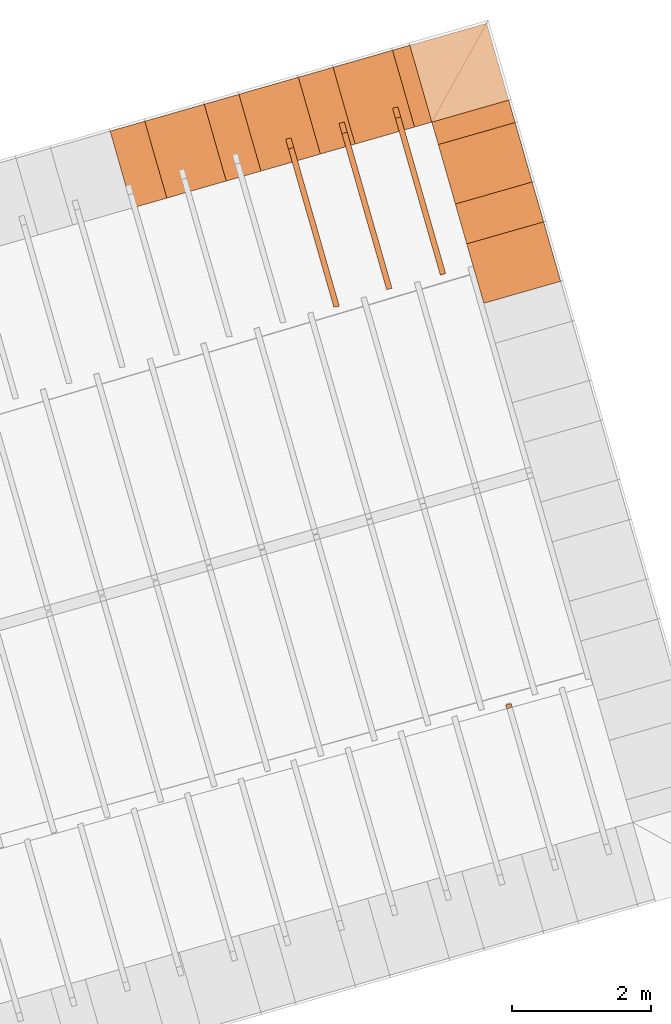
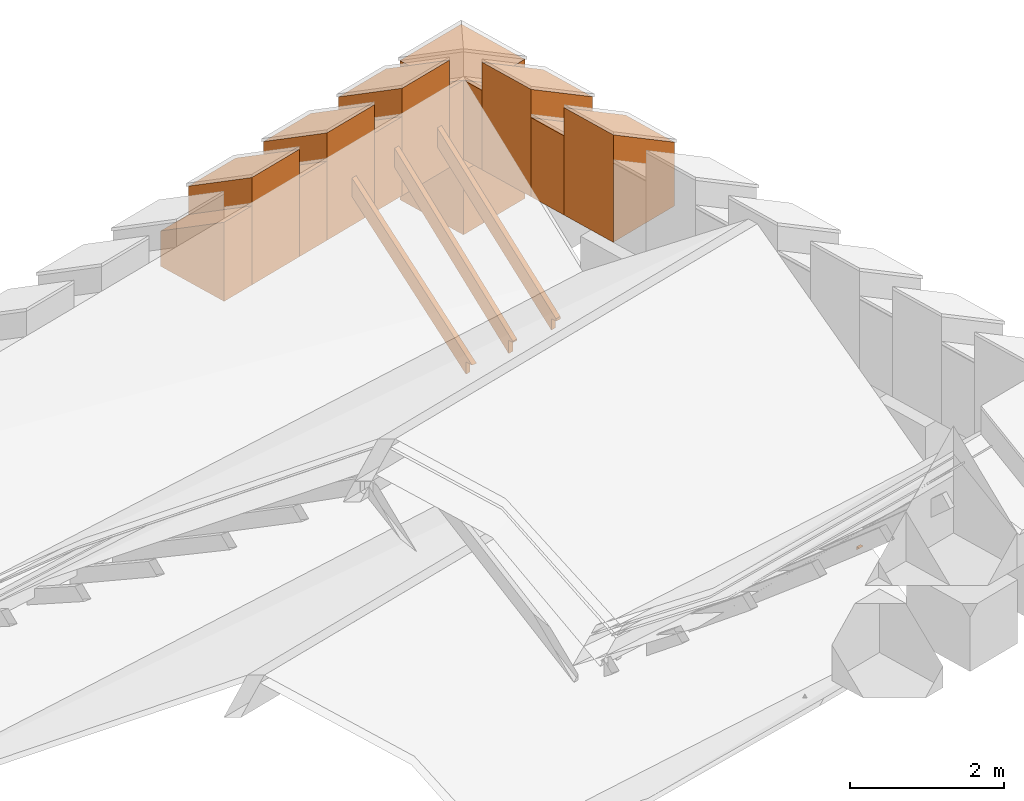
# One storey, part 10 of 10: 17 proxies.
"""IFC4 building model written with IfcOpenShell, lengths in metres."""

from ifc_helpers import new_model, entity, si_unit, converted_unit, derived_unit, direction, frame, origin_with_axes, place, context, subcontext, project, spatial, polygons, material, type_object, element, save


model = new_model("IFC4")

# Units and contexts
model_context = context("Model", 3, precision=1e-05, world=origin_with_axes(), true_north=direction((0.0, 1.0)))
body_context = subcontext(model_context, "Body", "Model", "MODEL_VIEW")
ifc_project = project(units=[si_unit("LENGTHUNIT", "METRE"), si_unit("AREAUNIT", "SQUARE_METRE"), si_unit("VOLUMEUNIT", "CUBIC_METRE"), converted_unit("PLANEANGLEUNIT", "DEGREE", entity("IfcPlaneAngleMeasure", 0.0174532925199433), si_unit("PLANEANGLEUNIT", "RADIAN"), dimensions=[0, 0, 0, 0, 0, 0, 0]), converted_unit("TIMEUNIT", "Year", entity("IfcTimeMeasure", 31557600.0), si_unit("TIMEUNIT", "SECOND"), dimensions=[0, 0, 1, 0, 0, 0, 0]), si_unit("MASSUNIT", "GRAM", prefix="KILO"), si_unit("THERMODYNAMICTEMPERATUREUNIT", "DEGREE_CELSIUS"), si_unit("LUMINOUSINTENSITYUNIT", "LUMEN"), si_unit("ENERGYUNIT", "JOULE", prefix="MEGA"), derived_unit("THERMALCONDUCTANCEUNIT", [(si_unit("POWERUNIT", "WATT"), 1), (si_unit("LENGTHUNIT", "METRE"), -1), (si_unit("THERMODYNAMICTEMPERATUREUNIT", "KELVIN"), -1)]), derived_unit("SPECIFICHEATCAPACITYUNIT", [(si_unit("ENERGYUNIT", "JOULE"), 1), (si_unit("MASSUNIT", "GRAM", prefix="KILO"), -1), (si_unit("THERMODYNAMICTEMPERATUREUNIT", "KELVIN"), -1)]), derived_unit("MASSDENSITYUNIT", [(si_unit("MASSUNIT", "GRAM", prefix="KILO"), 1), (si_unit("VOLUMEUNIT", "CUBIC_METRE"), -1)])], contexts=[model_context])

# Site, building, storey
site_placement = place(None, frame((0.0, 0.0, 0.0), z_axis=(0.0, 0.0, 1.0), x_axis=(0.9612616959383189, 0.2756373558169991, 0.0)))
site = spatial("IfcSite", under=ifc_project, at=site_placement, CompositionType="ELEMENT")
building_placement = place(site_placement, origin_with_axes())
building = spatial("IfcBuilding", under=site, at=building_placement, CompositionType="ELEMENT")
storey_placement = place(building_placement, frame((0.0, 0.0, 11.0), z_axis=(0.0, 0.0, 1.0), x_axis=(1.0, 0.0, 0.0)))
storey = spatial("IfcBuildingStorey", under=building, at=storey_placement, Name="Dach", CompositionType="ELEMENT", Elevation=11.0)

# Proxies
ifc_material_1 = material()
building_element_proxy_type_1 = type_object("IfcBuildingElementProxyType", PredefinedType="NOTDEFINED")
proxy_1_placement = place(storey_placement, frame((-32.67063236374476, 25.87969375484247, -11.3285), z_axis=(0.0, 0.0, 1.0), x_axis=(-1.0, 0.0, 0.0)))
element("IfcBuildingElementProxy", 1, at=proxy_1_placement, inside=storey, type_object=building_element_proxy_type_1, material=ifc_material_1, Name="008", PredefinedType="NOTDEFINED", context=body_context, shape_type="Tessellation", body=[
    polygons([(-61.03241932296884, 7.381130212056575, 12.29306372087191), (-61.03241932296885, 9.787341089745906, 10.16911174696492), (-61.03241932296885, 9.787341089745906, 10.36694133970042), (-61.03241932296884, 9.89566501934427, 10.36694133970042), (-61.03241932296884, 7.526718754969066, 12.458), (-61.11241932296884, 7.381130212056575, 12.29306372087191), (-61.11241932296885, 9.787341089745906, 10.16911174696491), (-61.11241932296885, 9.787341089745906, 10.36106354189202), (-61.11241932296884, 9.90232393687027, 10.36106354189202), (-61.11241932296884, 7.526718754969066, 12.458)], [[[1, 2, 3, 4, 5]], [[1, 6, 7, 2]], [[2, 7, 8, 3]], [[3, 8, 9, 4]], [[4, 9, 10, 5]], [[5, 10, 6, 1]], [[6, 10, 9, 8, 7]]], closed=True),
])
proxy_2_placement = place(storey_placement, frame((-32.67063236374476, 25.87969375484247, -11.3285), z_axis=(0.0, 0.0, 1.0), x_axis=(-1.0, 0.0, 0.0)))
element("IfcBuildingElementProxy", 2, at=proxy_2_placement, inside=storey, type_object=building_element_proxy_type_1, material=ifc_material_1, Name="008", PredefinedType="NOTDEFINED", context=body_context, shape_type="Tessellation", body=[
    polygons([(-62.63241932296884, 7.377252049091295, 12.29656981746263), (-62.63241932296887, 9.787341089745905, 10.065090771124), (-62.63241932296887, 9.787341089745906, 10.24938538353242), (-62.63241932296887, 9.872561772591819, 10.24938538353242), (-62.63241932296887, 9.871470519104868, 10.28701613082583), (-62.63241932296884, 7.526718754969065, 12.458), (-62.71241932296884, 7.377252049091294, 12.29656981746263), (-62.71241932296887, 9.787341089745905, 10.06509077112399), (-62.71241932296893, 9.787341089745906, 10.24350758572401), (-62.71241932296887, 9.872732222763963, 10.24350758572402), (-62.71241932296887, 9.871470519104868, 10.28701613082583), (-62.71241932296884, 7.526718754969064, 12.458)], [[[1, 2, 3, 4, 5, 6]], [[1, 7, 8, 2]], [[2, 8, 9, 3]], [[3, 9, 10, 4]], [[4, 10, 11, 5]], [[5, 11, 12, 6]], [[6, 12, 7, 1]], [[7, 12, 11, 10, 9, 8]]], closed=True),
])
proxy_3_placement = place(storey_placement, frame((-32.67063236374476, 25.87969375484247, -11.3285), z_axis=(0.0, 0.0, 1.0), x_axis=(-1.0, 0.0, 0.0)))
element("IfcBuildingElementProxy", 3, at=proxy_3_placement, inside=storey, type_object=building_element_proxy_type_1, material=ifc_material_1, Name="008", PredefinedType="NOTDEFINED", context=body_context, shape_type="Tessellation", body=[
    polygons([(-61.83241932296884, 7.37530678639323, 12.38177859929889), (-61.83241932296882, 9.787341089745905, 10.09359130616137), (-61.83241932296882, 9.787341089745906, 10.30816336161642), (-61.83241932296882, 9.861835376853213, 10.30816336161642), (-61.83241932296882, 9.862634373866781, 10.32540870856656), (-61.83241932296884, 7.526718754969063, 12.5413856660973), (-61.91241932296884, 7.375306786393231, 12.38177859929889), (-61.91241932296882, 9.787341089745905, 10.09359130616137), (-61.91241932296883, 9.787341089745906, 10.30228556380802), (-61.91241932296882, 9.861563051633615, 10.30228556380802), (-61.91241932296882, 9.862634373866783, 10.32540870856656), (-61.91241932296884, 7.526718754969063, 12.5413856660973)], [[[1, 2, 3, 4, 5, 6]], [[1, 7, 8, 2]], [[2, 8, 9, 3]], [[3, 9, 10, 4]], [[4, 10, 11, 5]], [[5, 11, 12, 6]], [[6, 12, 7, 1]], [[7, 12, 11, 10, 9, 8]]], closed=True),
])
proxy_4_placement = place(storey_placement, frame((-32.66955969550476, -0.05131726657445945, -11.3285), z_axis=(0.0, 0.0, 1.0), x_axis=(1.0, 0.0, 0.0)))
element("IfcBuildingElementProxy", 4, at=proxy_4_placement, inside=storey, type_object=building_element_proxy_type_1, material=ifc_material_1, Name="008", PredefinedType="NOTDEFINED", context=body_context, shape_type="Tessellation", body=[
    polygons([(61.83241932296882, 9.79368791837926, 10.08757035836209), (61.83241932296882, 9.849176209681753, 10.03493113888673), (61.91241932296882, 9.849176209681753, 10.03493113888673), (61.91241932296882, 9.799883849098983, 10.08169256055369), (61.83241932296882, 9.851615046040278, 10.08757035836209), (61.91241932296882, 9.851342720820679, 10.08169256055369)], [[[1, 2, 3, 4]], [[2, 1, 5]], [[3, 2, 5, 6]], [[4, 3, 6]], [[5, 1, 4, 6]]], closed=True),
])
ifc_material_2 = material()
building_element_proxy_type_2 = type_object("IfcBuildingElementProxyType", Name="336 x 1150", PredefinedType="NOTDEFINED")
proxy_5_placement = place(storey_placement, frame((31.02643139080753, 17.98844342391578, 0.2019994110307355), z_axis=(0.0, 0.0, 1.0), x_axis=(0.0, 1.0, 0.0)))
element("IfcBuildingElementProxy", 5, at=proxy_5_placement, inside=storey, type_object=building_element_proxy_type_2, material=ifc_material_2, PredefinedType="NOTDEFINED", context=body_context, shape_type="Tessellation", body=[
    polygons([(-0.168202742070406, -0.5749999999999993, 0.5616599571312832), (-0.168202742070406, -0.5749999999999993, 0.0), (0.168202742070406, -0.5749999999999993, 0.0), (0.168202742070406, -0.5749999999999993, 0.5616599571312832), (-0.1682027420704095, 0.5749999999999993, 1.258340042868717), (-0.1682027420704095, 0.5749999999999993, 0.0), (0.1682027420704024, 0.5749999999999993, 0.0), (0.1682027420704024, 0.5749999999999993, 1.258340042868717)], [[[1, 2, 3, 4]], [[5, 6, 2, 1]], [[3, 2, 6, 7]], [[4, 3, 7, 8]], [[5, 1, 4, 8]], [[8, 7, 6, 5]]], closed=True),
])
building_element_proxy_type_3 = type_object("IfcBuildingElementProxyType", Name="259 x 1150", PredefinedType="NOTDEFINED")
proxy_6_placement = place(storey_placement, frame((30.32195058259141, 18.73164616582989, 0.2019994110307355), z_axis=(0.0, 0.0, 1.0), x_axis=(-1.0, -4.799646136429001e-09, 0.0)))
element("IfcBuildingElementProxy", 6, at=proxy_6_placement, inside=storey, type_object=building_element_proxy_type_3, material=ifc_material_2, PredefinedType="NOTDEFINED", context=body_context, shape_type="Tessellation", body=[
    polygons([(0.1294808085213504, 0.5749999999999993, 1.258340042868713), (0.1294808085213504, 0.5749999999999993, 0.0), (-0.1294808085213468, 0.5749999999999993, 0.0), (-0.1294808085213468, 0.5749999999999993, 1.258340042868713), (0.1294808085213504, -0.5749999999999993, 0.5616599571312779), (0.1294808085213504, -0.5749999999999993, 0.0), (-0.1294808085213468, -0.5749999999999993, 0.0), (-0.1294808085213468, -0.5749999999999993, 0.5616599571312779)], [[[1, 2, 3, 4]], [[5, 6, 2, 1]], [[3, 2, 6, 7]], [[4, 3, 7, 8]], [[5, 1, 4, 8]], [[8, 7, 6, 5]]], closed=True),
])
building_element_proxy_type_4 = type_object("IfcBuildingElementProxyType", Name="1150 x 1150", PredefinedType="NOTDEFINED")
proxy_7_placement = place(storey_placement, frame((31.02643138835298, 18.73164616645136, 0.2019994110307373), z_axis=(0.0, 0.0, 1.0), x_axis=(0.0, 1.0, 0.0)))
element("IfcBuildingElementProxy", 7, at=proxy_7_placement, inside=storey, type_object=building_element_proxy_type_4, material=ifc_material_2, PredefinedType="NOTDEFINED", context=body_context, shape_type="Tessellation", body=[
    polygons([(-0.5749999999999993, -0.5750000000000028, 1.011699999999999), (-0.5749999999999993, -0.5750000000000028, 0.0), (0.5749999999999993, -0.5749999999999993, 0.0), (0.5749999999999993, -0.5749999999999993, 1.011699999999999), (-0.5750000000000028, 0.5749999999999957, 1.011699999999999), (-0.5750000000000028, 0.5749999999999957, 0.0), (0.5749999999999957, 0.5749999999999993, 0.0), (0.5749999999999957, 0.5749999999999993, 1.011699999999999)], [[[1, 2, 3, 4]], [[5, 6, 2, 1]], [[3, 2, 6, 7]], [[4, 3, 7, 8]], [[5, 1, 4, 8]], [[8, 7, 6, 5]]], closed=True),
])
building_element_proxy_type_5 = type_object("IfcBuildingElementProxyType", Name="519 x 1150", PredefinedType="NOTDEFINED")
proxy_8_placement = place(storey_placement, frame((26.22507181500691, 18.73164615625302, 0.2019994076779703), z_axis=(0.0, 0.0, 1.0), x_axis=(-1.0, -4.799646136429001e-09, 0.0)))
element("IfcBuildingElementProxy", 8, at=proxy_8_placement, inside=storey, type_object=building_element_proxy_type_5, material=ifc_material_2, PredefinedType="NOTDEFINED", context=body_context, shape_type="Tessellation", body=[
    polygons([(0.2594837734777791, 0.5750000000000028, 1.258340042868717), (0.2594837734777791, 0.5750000000000028, 0.0), (-0.2594837734777791, 0.5749999999999993, 0.0), (-0.2594837734777791, 0.5749999999999993, 1.258340042868717), (0.2594837734777826, -0.5749999999999993, 0.5616599571312832), (0.2594837734777826, -0.5749999999999993, 0.0), (-0.2594837734777755, -0.5750000000000028, 0.0), (-0.2594837734777755, -0.5750000000000028, 0.5616599571312832)], [[[1, 2, 3, 4]], [[5, 6, 2, 1]], [[3, 2, 6, 7]], [[4, 3, 7, 8]], [[5, 1, 4, 8]], [[8, 7, 6, 5]]], closed=True),
])
proxy_9_placement = place(storey_placement, frame((27.63402801512536, 18.73164615605913, 0.2019994076779703), z_axis=(0.0, 0.0, 1.0), x_axis=(-1.0, -4.799646136429001e-09, 0.0)))
element("IfcBuildingElementProxy", 9, at=proxy_9_placement, inside=storey, type_object=building_element_proxy_type_5, material=ifc_material_2, PredefinedType="NOTDEFINED", context=body_context, shape_type="Tessellation", body=[
    polygons([(0.2594791373954948, 0.5749999999999993, 1.258340042868717), (0.2594791373954948, 0.5749999999999993, 0.0), (-0.2594791373954912, 0.5749999999999993, 0.0), (-0.2594791373954912, 0.5749999999999993, 1.258340042868717), (0.2594791373954948, -0.5749999999999993, 0.5616599571312832), (0.2594791373954948, -0.5749999999999993, 0.0), (-0.2594791373954912, -0.5749999999999993, 0.0), (-0.2594791373954912, -0.5749999999999993, 0.5616599571312832)], [[[1, 2, 3, 4]], [[5, 6, 2, 1]], [[3, 2, 6, 7]], [[4, 3, 7, 8]], [[5, 1, 4, 8]], [[8, 7, 6, 5]]], closed=True),
])
proxy_10_placement = place(storey_placement, frame((29.04298885152618, 18.73164616282165, 0.2019994076779703), z_axis=(0.0, 0.0, 1.0), x_axis=(-1.0, -4.799646136429001e-09, 0.0)))
element("IfcBuildingElementProxy", 10, at=proxy_10_placement, inside=storey, type_object=building_element_proxy_type_5, material=ifc_material_2, PredefinedType="NOTDEFINED", context=body_context, shape_type="Tessellation", body=[
    polygons([(0.2594791373209446, 0.5749999999999993, 1.258340042868717), (0.2594791373209446, 0.5749999999999993, 0.0), (-0.2594791373209411, 0.5750000000000028, 0.0), (-0.2594791373209411, 0.5750000000000028, 1.258340042868717), (0.2594791373209446, -0.5749999999999993, 0.5616599571312832), (0.2594791373209446, -0.5749999999999993, 0.0), (-0.2594791373209411, -0.5749999999999957, 0.0), (-0.2594791373209411, -0.5749999999999957, 0.5616599571312832)], [[[1, 2, 3, 4]], [[5, 6, 2, 1]], [[3, 2, 6, 7]], [[4, 3, 7, 8]], [[5, 1, 4, 8]], [[8, 7, 6, 5]]], closed=True),
])
building_element_proxy_type_6 = type_object("IfcBuildingElementProxyType", Name="596 x 1150", PredefinedType="NOTDEFINED")
proxy_11_placement = place(storey_placement, frame((31.02643138426657, 16.63203833985381, 0.2019994076779685), z_axis=(0.0, 0.0, 1.0), x_axis=(0.0, 1.0, 0.0)))
element("IfcBuildingElementProxy", 11, at=proxy_11_placement, inside=storey, type_object=building_element_proxy_type_6, material=ifc_material_2, PredefinedType="NOTDEFINED", context=body_context, shape_type="Tessellation", body=[
    polygons([(-0.2982000000000014, -0.5749999999999993, 0.5616599571312832), (-0.2982000000000014, -0.5749999999999993, 0.0), (0.2981999999999978, -0.5750000000000028, 0.0), (0.2981999999999978, -0.5750000000000028, 0.5616599571312832), (-0.2982000000000014, 0.5749999999999993, 1.258340042868717), (-0.2982000000000014, 0.5749999999999993, 0.0), (0.2981999999999978, 0.5749999999999957, 0.0), (0.2981999999999978, 0.5749999999999957, 1.258340042868717)], [[[1, 2, 3, 4]], [[5, 6, 2, 1]], [[3, 2, 6, 7]], [[4, 3, 7, 8]], [[5, 1, 4, 8]], [[8, 7, 6, 5]]], closed=True),
])
building_element_proxy_type_7 = type_object("IfcBuildingElementProxyType", Name="890 x 1150", PredefinedType="NOTDEFINED")
proxy_12_placement = place(storey_placement, frame((31.02643138426656, 17.37523962070142, 0.2019994076779703), z_axis=(0.0, 0.0, 1.0), x_axis=(0.0, 1.0, 0.0)))
element("IfcBuildingElementProxy", 12, at=proxy_12_placement, inside=storey, type_object=building_element_proxy_type_7, material=ifc_material_2, PredefinedType="NOTDEFINED", context=body_context, shape_type="Tessellation", body=[
    polygons([(-0.4450012808476238, -0.5749999999999993, 1.011659957131286), (-0.4450012808476238, -0.5749999999999993, 0.0), (0.4450012808476238, -0.5750000000000028, 0.0), (0.4450012808476238, -0.5750000000000028, 1.011659957131286), (-0.4450012808476274, 0.5750000000000028, 1.70834004286872), (-0.4450012808476274, 0.5750000000000028, 0.0), (0.4450012808476203, 0.5749999999999993, 0.0), (0.4450012808476203, 0.5749999999999993, 1.70834004286872)], [[[1, 2, 3, 4]], [[5, 6, 2, 1]], [[3, 2, 6, 7]], [[4, 3, 7, 8]], [[5, 1, 4, 8]], [[8, 7, 6, 5]]], closed=True),
])
proxy_13_placement = place(storey_placement, frame((31.0264313844179, 15.88883435579911, 0.2019994076779703), z_axis=(0.0, 0.0, 1.0), x_axis=(0.0, 1.0, 0.0)))
element("IfcBuildingElementProxy", 13, at=proxy_13_placement, inside=storey, type_object=building_element_proxy_type_7, material=ifc_material_2, PredefinedType="NOTDEFINED", context=body_context, shape_type="Tessellation", body=[
    polygons([(-0.4450012808476238, -0.5749999999999993, 1.011659957131286), (-0.4450012808476238, -0.5749999999999993, 0.0), (0.4450012808476238, -0.5749999999999993, 0.0), (0.4450012808476238, -0.5749999999999993, 1.011659957131286), (-0.4450012808476238, 0.5750000000000028, 1.70834004286872), (-0.4450012808476238, 0.5750000000000028, 0.0), (0.4450012808476238, 0.5750000000000028, 0.0), (0.4450012808476238, 0.5750000000000028, 1.70834004286872)], [[[1, 2, 3, 4]], [[5, 6, 2, 1]], [[3, 2, 6, 7]], [[4, 3, 7, 8]], [[5, 1, 4, 8]], [[8, 7, 6, 5]]], closed=True),
])
for number, where, z_axis, x_axis in (
    (14, (29.74746926935123, 18.73164616179102, 0.2019994076779703), (0.0, 0.0, 1.0), (-1.0, -4.202208037436403e-09, 0.0)),
    (15, (28.3385084330186, 18.73164615900065, 0.2019994076779703), (0.0, 0.0, 1.0), (-1.0, -4.202208037436403e-09, 0.0)),
):
    element("IfcBuildingElementProxy", number, at=place(storey_placement, frame(where, z_axis=z_axis, x_axis=x_axis)), inside=storey, type_object=building_element_proxy_type_7, material=ifc_material_2, PredefinedType="NOTDEFINED", context=body_context, shape_type="Tessellation", body=[
        polygons([(0.4450012808476238, 0.5749999999999993, 1.708340042868716), (0.4450012808476238, 0.5749999999999993, 0.0), (-0.4450012808476274, 0.5749999999999993, 0.0), (-0.4450012808476274, 0.5749999999999993, 1.708340042868716), (0.4450012808476238, -0.5749999999999993, 1.011659957131281), (0.4450012808476238, -0.5749999999999993, 0.0), (-0.4450012808476274, -0.5749999999999993, 0.0), (-0.4450012808476274, -0.5749999999999993, 1.011659957131281)], [[[1, 2, 3, 4]], [[5, 6, 2, 1]], [[3, 2, 6, 7]], [[4, 3, 7, 8]], [[5, 1, 4, 8]], [[8, 7, 6, 5]]], closed=True),
    ])
proxy_14_placement = place(storey_placement, frame((26.92954759668598, 18.73164615621027, 0.2019994076779703), z_axis=(0.0, 0.0, 1.0), x_axis=(-1.0, -4.202208037436403e-09, 0.0)))
element("IfcBuildingElementProxy", 16, at=proxy_14_placement, inside=storey, type_object=building_element_proxy_type_7, material=ifc_material_2, PredefinedType="NOTDEFINED", context=body_context, shape_type="Tessellation", body=[
    polygons([(0.4450012808476238, 0.5749999999999993, 1.70834004286872), (0.4450012808476238, 0.5749999999999993, 0.0), (-0.4450012808476274, 0.5749999999999993, 0.0), (-0.4450012808476274, 0.5749999999999993, 1.70834004286872), (0.4450012808476238, -0.5749999999999993, 1.011659957131286), (0.4450012808476238, -0.5749999999999993, 0.0), (-0.4450012808476274, -0.5749999999999993, 0.0), (-0.4450012808476274, -0.5749999999999993, 1.011659957131286)], [[[1, 2, 3, 4]], [[5, 6, 2, 1]], [[3, 2, 6, 7]], [[4, 3, 7, 8]], [[5, 1, 4, 8]], [[8, 7, 6, 5]]], closed=True),
])
building_element_proxy_type_8 = type_object("IfcBuildingElementProxyType", PredefinedType="NOTDEFINED")
proxy_15_placement = place(storey_placement, frame((0.0, 0.0, -31.0), z_axis=(0.0, 0.0, 1.0), x_axis=(1.0, 0.0, 0.0)))
element("IfcBuildingElementProxy", 17, at=proxy_15_placement, inside=storey, type_object=building_element_proxy_type_8, material=ifc_material_2, PredefinedType="NOTDEFINED", context=body_context, shape_type="Tessellation", body=[
    polygons([(30.45143138411525, 18.15664616645135, 30.0), (30.45143138411521, 19.30664616645135, 30.0), (31.60143138411521, 19.30664616645139, 30.0), (31.60143138411524, 18.15664616645139, 30.0), (30.45143138411525, 18.15664616645135, 31.0117), (30.45143138411521, 19.30664616645135, 31.0117), (31.60143138411521, 19.30664616645139, 31.0117), (31.60143138411524, 18.15664616645139, 31.0117)], [[[1, 2, 3, 4]], [[1, 5, 6, 2]], [[2, 6, 7, 3]], [[4, 3, 7, 8]], [[5, 1, 4, 8]], [[5, 8, 7, 6]]], closed=True),
])

save(model, "model.ifc")
